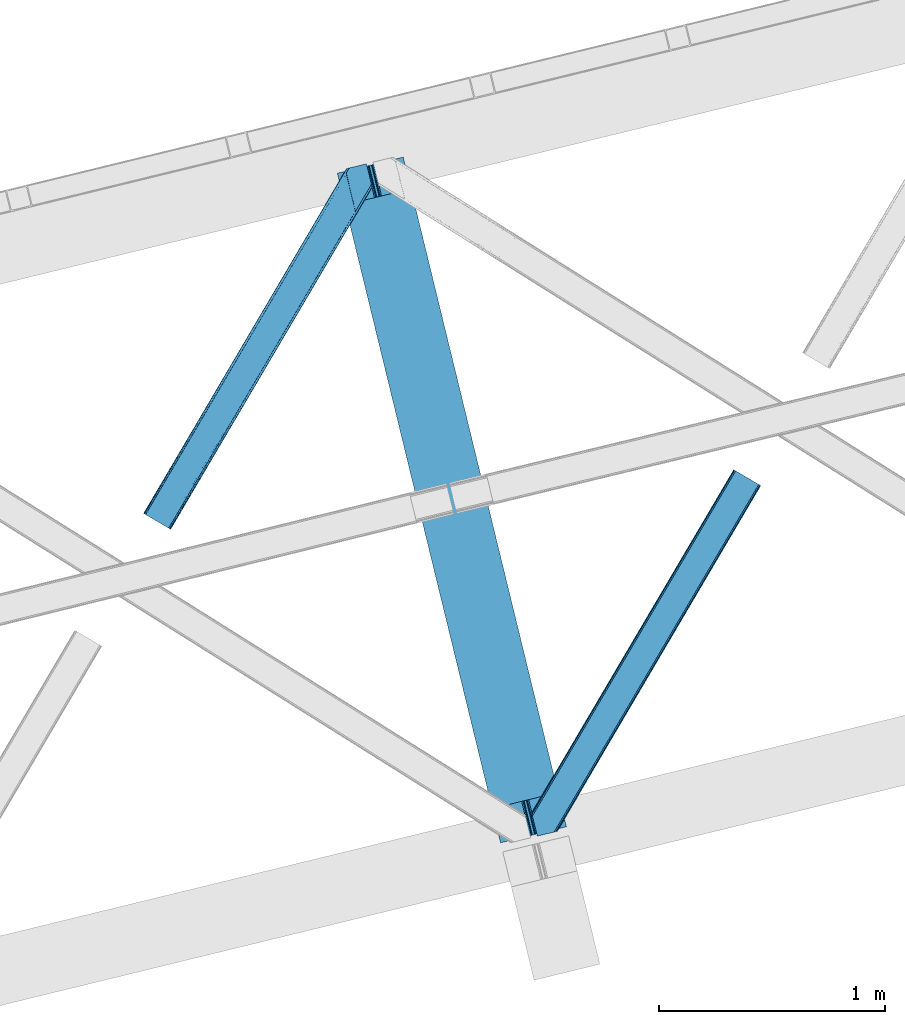
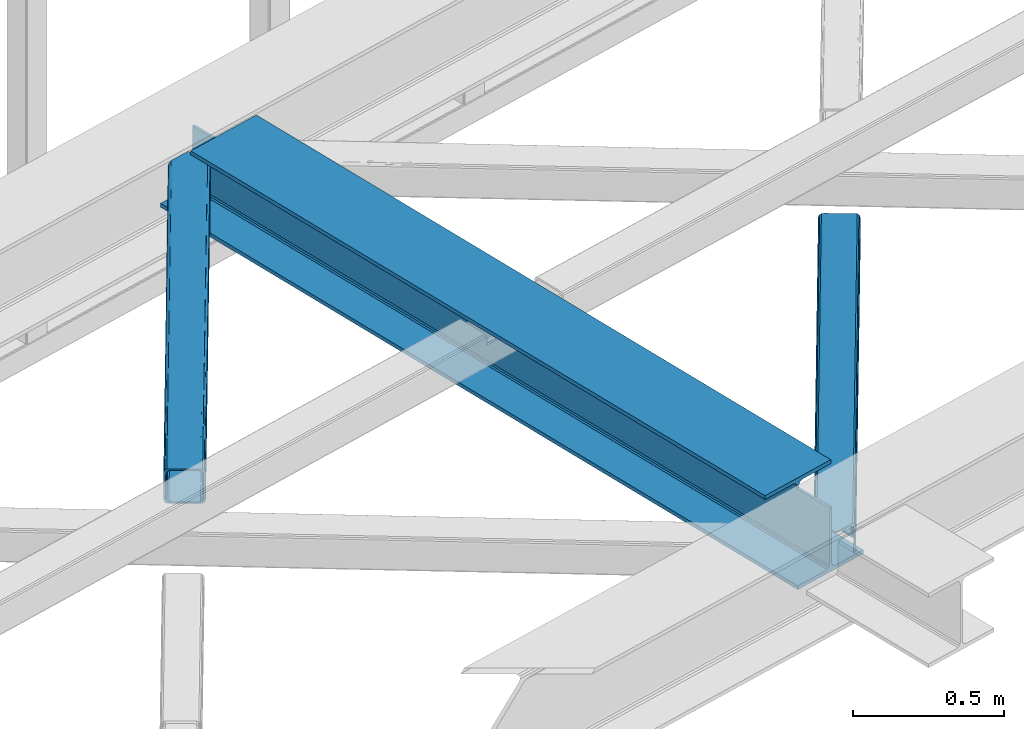
# One storey, part 19 of 66: 2 members, 1 beam.
"""IFC4 building model written with IfcOpenShell, lengths in millimetres."""

from ifc_helpers import new_model, entity, si_unit, converted_unit, derived_unit, direction, frame, origin, place, context, subcontext, project, spatial, triangles, polygons, material, type_object, element, save


model = new_model("IFC4")

# Units and contexts
model_context = context("Model", 3, precision=0.01, world=origin(), true_north=direction((6.12303176911189e-17, 1.0)))
plan_context = context("Plan", 3, precision=0.01, world=origin(), true_north=direction((6.12303176911189e-17, 1.0)))
body_context = subcontext(model_context, "Body", "Model", "MODEL_VIEW")
ifc_project = project(units=[si_unit("LENGTHUNIT", "METRE", prefix="MILLI"), si_unit("AREAUNIT", "SQUARE_METRE"), si_unit("VOLUMEUNIT", "CUBIC_METRE"), converted_unit("PLANEANGLEUNIT", "DEGREE", entity("IfcRatioMeasure", 0.0174532925199433), si_unit("PLANEANGLEUNIT", "RADIAN"), dimensions=[0, 0, 0, 0, 0, 0, 0]), si_unit("MASSUNIT", "GRAM", prefix="KILO"), derived_unit("MASSDENSITYUNIT", [(si_unit("MASSUNIT", "GRAM", prefix="KILO"), 1), (si_unit("LENGTHUNIT", "METRE"), -3)]), derived_unit("MOMENTOFINERTIAUNIT", [(si_unit("LENGTHUNIT", "METRE"), 4)]), si_unit("TIMEUNIT", "SECOND"), si_unit("FREQUENCYUNIT", "HERTZ"), si_unit("THERMODYNAMICTEMPERATUREUNIT", "DEGREE_CELSIUS"), derived_unit("THERMALTRANSMITTANCEUNIT", [(si_unit("MASSUNIT", "GRAM", prefix="KILO"), 1), (si_unit("THERMODYNAMICTEMPERATUREUNIT", "KELVIN"), -1), (si_unit("TIMEUNIT", "SECOND"), -3)]), derived_unit("VOLUMETRICFLOWRATEUNIT", [(si_unit("LENGTHUNIT", "METRE"), 3), (si_unit("TIMEUNIT", "SECOND"), -1)]), derived_unit("MASSFLOWRATEUNIT", [(si_unit("MASSUNIT", "GRAM", prefix="KILO"), 1), (si_unit("TIMEUNIT", "SECOND"), -1)]), derived_unit("ROTATIONALFREQUENCYUNIT", [(si_unit("TIMEUNIT", "SECOND"), -1)]), si_unit("ELECTRICCURRENTUNIT", "AMPERE"), si_unit("ELECTRICVOLTAGEUNIT", "VOLT"), si_unit("POWERUNIT", "WATT"), si_unit("FORCEUNIT", "NEWTON", prefix="KILO"), si_unit("ILLUMINANCEUNIT", "LUX"), si_unit("LUMINOUSFLUXUNIT", "LUMEN"), si_unit("LUMINOUSINTENSITYUNIT", "CANDELA"), derived_unit("USERDEFINED", [(si_unit("MASSUNIT", "GRAM", prefix="KILO"), -1), (si_unit("LENGTHUNIT", "METRE"), -2), (si_unit("TIMEUNIT", "SECOND"), 3), (si_unit("LUMINOUSFLUXUNIT", "LUMEN"), 1)]), derived_unit("LINEARVELOCITYUNIT", [(si_unit("LENGTHUNIT", "METRE"), 1), (si_unit("TIMEUNIT", "SECOND"), -1)]), si_unit("PRESSUREUNIT", "PASCAL"), derived_unit("USERDEFINED", [(si_unit("LENGTHUNIT", "METRE"), -2), (si_unit("MASSUNIT", "GRAM", prefix="KILO"), 1), (si_unit("TIMEUNIT", "SECOND"), -2)]), derived_unit("LINEARFORCEUNIT", [(si_unit("MASSUNIT", "GRAM", prefix="KILO"), 1), (si_unit("LENGTHUNIT", "METRE"), 1), (si_unit("TIMEUNIT", "SECOND"), -2), (si_unit("LENGTHUNIT", "METRE"), -1)]), derived_unit("PLANARFORCEUNIT", [(si_unit("MASSUNIT", "GRAM", prefix="KILO"), 1), (si_unit("LENGTHUNIT", "METRE"), 1), (si_unit("TIMEUNIT", "SECOND"), -2), (si_unit("LENGTHUNIT", "METRE"), -2)])], contexts=[model_context, plan_context])

# Site, building, storey
site_placement = place(None, origin())
site = spatial("IfcSite", under=ifc_project, at=site_placement, CompositionType="ELEMENT")
building_placement = place(site_placement, origin())
building = spatial("IfcBuilding", under=site, at=building_placement, CompositionType="ELEMENT")
storey_placement = place(building_placement, frame((0.0, 0.0, 19800.0)))
storey = spatial("IfcBuildingStorey", under=building, at=storey_placement, Name="06", CompositionType="ELEMENT", Elevation=19800.0)

# Beam
ifc_material = material(Name="Metal painted (White)")
beam_type = type_object("IfcBeamType", PredefinedType="BEAM")
beam_placement = place(storey_placement, frame((-58234.78, 3608.48, 3807.02)))
element("IfcBeam", 1, at=beam_placement, inside=storey, type_object=beam_type, material=ifc_material, ObjectType="Steel Beam", PredefinedType="BEAM", context=body_context, shape_type="Tessellation", body=[
    polygons([(291.465617442438, 3033.06716515592, 15.5000000000008), (1013.48916844672, 71.047827897101, 15.5000000000008), (1013.48916844672, 71.047827897101, 0.0), (291.465617442438, 3033.06716515592, 0.0), (168.078506058465, 3002.99025134615, 15.5000000000008), (890.102057062761, 40.9709140873291, 15.5000000000008), (883.409713288798, 39.3395844888243, 16.8701684147984), (161.386162284511, 3001.35892174764, 16.8701684147984), (877.736218188182, 37.9566100336502, 20.7720779386434), (155.712667183895, 2999.97594729247, 20.7720779386434), (873.945309959616, 37.0325360459167, 26.6116982174294), (151.92175895532, 2999.05187330474, 26.6116982174294), (872.614120016219, 36.7080444135018, 33.500000000001), (150.590569011932, 2998.72738167232, 33.500000000001), (140.875048430505, 2996.35912074242, 33.500000000001), (140.875048430505, 2996.35912074242, 259.000000000002), (150.590569011932, 2998.72738167232, 259.000000000002), (0.0, 2962.01933725882, 0.0), (0.0, 2962.01933725882, 15.4999999999965), (123.387111383964, 2992.09625106859, 15.5000000000008), (130.079455157926, 2993.7275806671, 16.8701684147984), (135.752950258542, 2995.11055512227, 20.7720779386434), (139.543858487109, 2996.03462911, 26.6116982174294), (862.898599434792, 34.3397834835981, 259.000000000002), (862.898599434792, 34.3397834835992, 33.500000000001), (861.567409491404, 34.0152918511837, 26.6116982174294), (857.776501262829, 33.0912178634502, 20.7720779386434), (852.103006162213, 31.7082434082767, 16.8701684147984), (845.410662388251, 30.0769138097719, 15.5000000000008), (722.023551004287, 0.0, 15.4999999999965), (722.023551004287, 5.41433564649196e-13, 0.0), (872.614120016219, 36.7080444135018, 259.000000000002), (184.336875281427, 2860.28691509782, 264.979820882044), (184.752732925781, 2858.58099728541, 264.979776108577), (184.752732925781, 2858.58099728541, 266.5), (835.611083878222, 188.508783434825, 266.500002998871), (835.611433998983, 188.507347130091, 260.000004007589), (835.756262659236, 187.913305519903, 259.069792895655), (184.10148419006, 2861.25277281279, 259.006343165873), (184.321671892423, 2860.34946683221, 259.617271795417), (175.037212344371, 2856.21273635551, 264.979776108577), (174.624287332073, 2857.90681193203, 264.979727889257), (174.621246070538, 2857.91909282363, 260.000048218074), (174.476547052887, 2858.51270029145, 259.069794411205), (826.131325439436, 185.173233288697, 259.006343169741), (825.907955396203, 186.089684915033, 259.617303331124), (825.895566552569, 186.140509148806, 266.500003008253), (175.037212344371, 2856.21273635551, 266.5), (173.706022400984, 2855.8882447231, 273.388301782572), (169.915114172408, 2854.96417073536, 279.227922061358), (164.241619071775, 2853.58119628019, 283.129831585203), (157.549275297821, 2851.94986668168, 284.5), (34.1621639138576, 2821.87295287191, 284.5), (34.1621639138576, 2821.87295287191, 300.000000000001), (325.627781356295, 2892.92078076901, 300.000000000001), (325.627781356295, 2892.92078076901, 284.5), (202.240669972323, 2862.84386695924, 284.5), (195.548326198377, 2861.21253736074, 283.129831585203), (189.874831097753, 2859.82956290556, 279.227922061358), (186.083922869178, 2858.90548891783, 273.388301782572), (836.942571748158, 188.832052879511, 273.388305639783), (840.732848336854, 189.758718051425, 279.227924098781), (846.405919284392, 191.143432515101, 283.129832400619), (853.098110965509, 192.775386045914, 284.500000377228), (976.485139653361, 222.852639101025, 284.500000138971), (976.483469846701, 222.859489169757, 299.999995328161), (685.018047749439, 151.810859905715, 299.999995890962), (685.019717556091, 151.804009836983, 284.500000701776), (808.406746243935, 181.881262892094, 284.500000463519), (815.099233140082, 183.512005358672, 283.129832461069), (820.773144788834, 184.893271003198, 279.227924137322), (824.564679575826, 185.814774652495, 273.388305663684)], [[[1, 2, 3, 4]], [[5, 6, 2, 1]], [[7, 6, 5, 8]], [[9, 7, 8, 10]], [[11, 9, 10, 12]], [[13, 11, 12, 14]], [[15, 16, 17, 14, 12, 10, 8, 5, 1, 4, 18, 19, 20, 21, 22, 23]], [[24, 25, 26, 27, 28, 29, 30, 31, 3, 2, 6, 7, 9, 11, 13, 32]], [[4, 3, 31, 18]], [[18, 31, 30, 19]], [[19, 30, 29, 20]], [[26, 25, 15, 23]], [[27, 26, 23, 22]], [[28, 27, 22, 21]], [[29, 28, 21, 20]], [[33, 34, 35, 36, 37, 38, 32, 13, 14, 17, 39, 40]], [[41, 42, 43, 44, 16, 15, 25, 24, 45, 46, 47, 48]], [[44, 39, 17, 16]], [[42, 33, 40, 43]], [[42, 41, 34, 33]], [[45, 24, 32, 38]], [[41, 48, 49, 50, 51, 52, 53, 54, 55, 56, 57, 58, 59, 60, 35, 34]], [[47, 46, 37, 36, 61, 62, 63, 64, 65, 66, 67, 68, 69, 70, 71, 72]], [[61, 36, 35, 60]], [[62, 61, 60, 59]], [[63, 62, 59, 58]], [[64, 63, 58, 57]], [[57, 56, 65, 64]], [[56, 55, 66, 65]], [[55, 54, 67, 66]], [[54, 53, 68, 67]], [[53, 52, 69, 68]], [[70, 69, 52, 51]], [[71, 70, 51, 50]], [[72, 71, 50, 49]], [[47, 72, 49, 48]]], closed=False),
])

# Members
member_type_1 = type_object("IfcMemberType", PredefinedType="BRACE")
member_1_placement = place(storey_placement, frame((-59092.24, 4994.99, 3824.0)))
element("IfcMember", 2, at=member_1_placement, inside=storey, type_object=member_type_1, ObjectType="Steel Horizontal Brace", PredefinedType="BRACE", context=body_context, shape_type="Tessellation", body=[
    triangles([(105.565649414064, 8.87794647216742, 0.0), (15.0828002929702, 62.1479507446284, 0.0), (892.847827148435, 1346.1393447876, 0.0), (857.170935058595, 1492.50250396728, 0.0), (854.896655273435, 1501.83739929199, 1.33247680664135), (9.31105957031104, 65.5459991455073, 1.33247680664135), (852.966540527341, 1509.75145111084, 5.12526855468968), (4.4183349609375, 68.4260559082031, 5.12526855468968), (851.678247070311, 1515.03950042725, 10.8039916992202), (1.14876708984229, 70.3509384155268, 10.8039916992202), (851.222460937497, 1516.89636383057, 17.5012573242202), (0.0, 71.0264785766603, 17.5012573242202), (893.638476562497, 1342.89768218994, 0.155804443358647), (111.337390136716, 5.48047943115216, 1.33247680664135), (899.559045410155, 1344.34119873047, 1.33247680664135), (912.390820312503, 1347.46949615478, 10.8039916992202), (914.195361328122, 1347.90958557129, 17.5012573242202), (120.643798828125, 0.0, 17.5012573242202), (119.499682617185, 0.675540161132631, 10.8039916992202), (907.251599121097, 1346.21666564941, 5.12526855468968), (116.230114746089, 2.59984130859357, 5.12526855468968), (902.498400878903, 1345.05743408203, 17.9802978515618), (893.638476562497, 1342.89768218994, 9.69243164062573), (897.768457031249, 1343.90459747314, 12.1248413085959), (903.726232910158, 1345.35625305176, 19.5011352539077), (914.195361328122, 1347.90958557129, 19.5011352539077), (1011.61732177735, 1513.38611297607, 19.5011352539077), (1008.98957519532, 1524.16103668213, 19.5011352539077), (1011.61732177735, 1513.38611297607, 122.499499511719), (120.643798828125, 0.0, 122.499499511719), (114.61160888672, 3.55094604492206, 24.5008300781265), (1009.24072265625, 1523.14365692139, 24.5008300781265), (113.46749267578, 4.22706756591742, 17.8035644531265), (110.197924804685, 6.15136871337836, 12.1248413085959), (105.305200195311, 9.03200683593695, 8.3320495605476), (99.5334594726519, 12.4294738769531, 6.99957275390625), (892.685046386716, 1346.79976959229, 8.8831787109375), (890.471228027345, 1355.89688873291, 6.99957275390625), (21.114990234375, 58.5970046997072, 6.99957275390625), (859.547534179685, 1482.74496002197, 6.99957275390625), (853.961828613283, 1505.65984039307, 18.501196289064), (851.222460937497, 1516.89636383057, 18.501196289064), (854.096704101561, 1505.10871124268, 17.8803039550803), (855.343139648438, 1499.99390716553, 12.1248413085959), (857.273254394531, 1492.07985534668, 8.3320495605476), (1009.24072265625, 1523.14365692139, 115.499926757813), (114.61160888672, 3.55094604492206, 115.499926757813), (1008.78493652344, 1525.00052032471, 122.197192382813), (113.46749267578, 4.22706756591742, 122.197192382813), (1007.49664306641, 1530.28856964111, 127.873590087893), (110.197924804685, 6.15136871337836, 127.873590087893), (1005.57117919922, 1538.20262145996, 131.668707275392), (105.305200195311, 9.03200683593695, 131.668707275392), (1003.29224853516, 1547.53751678467, 133.001184082033), (99.5334594726519, 12.4294738769531, 133.001184082033), (851.952648925784, 1518.13291625977, 19.5011352539077), (854.580395507815, 1507.35799255371, 19.5011352539077), (851.780566406247, 1517.83991088867, 19.2639404296897), (854.43156738281, 1506.94987792969, 19.2592895507805), (851.589880371095, 1517.51434936523, 19.0011657714858), (854.268786621091, 1506.50920715332, 19.0011657714858), (851.394543457034, 1517.1887878418, 18.7360656738274), (854.110656738281, 1506.06795501709, 18.7407165527366), (908.014343261719, 1598.12628936768, 19.5011352539077), (897.545214843747, 1595.57353820801, 19.5011352539077), (1011.16618652343, 1515.24297637939, 129.196765136719), (1009.8778930664, 1520.53160705566, 134.87548828125), (1008.43146972657, 1526.45624542236, 138.000878906252), (986.311889648438, 1617.21117095947, 138.000878906252), (986.311889648438, 1617.21117095947, 133.001184082033), (897.545214843747, 1595.57353820801, 122.499499511719), (0.0, 71.0264785766603, 122.499499511719), (7.18095703124709, 66.799411010742, 17.8035644531265), (10.4505249023423, 64.8751098632811, 12.1248413085959), (6.03218994140479, 67.4755325317383, 24.5008300781265), (907.028356933595, 1597.88560638428, 24.5008300781265), (15.3432495117158, 61.9944717407225, 8.3320495605476), (908.832897949222, 1598.32511444092, 122.197192382813), (899.349755859374, 1596.01362762451, 129.196765136719), (904.48897705078, 1597.26645812988, 134.87548828125), (930.738537597659, 1603.66490478516, 133.001184082033), (910.246765136719, 1598.66986083984, 138.000878906252), (921.664672851563, 1601.45341186523, 131.668707275392), (913.972119140628, 1599.57794494629, 127.873590087893), (907.028356933595, 1597.88560638428, 115.499926757813), (21.114990234375, 58.5970046997072, 133.001184082033), (6.03218994140479, 67.4755325317383, 115.499926757813), (15.3432495117158, 61.9944717407225, 131.668707275392), (10.4505249023423, 64.8751098632811, 127.873590087893), (7.18095703124709, 66.799411010742, 122.197192382813), (119.499682617185, 0.675540161132631, 129.196765136719), (116.230114746089, 2.59984130859357, 134.87548828125), (111.337390136716, 5.48047943115216, 138.668280029298), (105.565649414064, 8.87794647216742, 140.00075683594), (15.0828002929702, 62.1479507446284, 140.00075683594), (9.31105957031104, 65.5459991455073, 138.668280029298), (4.4183349609375, 68.4260559082031, 134.87548828125), (1.14876708984229, 70.3509384155268, 129.196765136719), (896.991760253906, 1576.15553741455, 138.000878906252), (938.18924560547, 1407.14434204102, 138.000878906252), (899.024194335936, 1563.5946762085, 140.00075683594), (897.042919921878, 1571.72266845703, 139.000817871096), (896.801074218747, 1573.13653564453, 138.638049316407), (896.926647949222, 1575.15443572998, 138.212493896484), (896.86153564453, 1574.14112548828, 138.426434326171), (937.477661132813, 1407.08562469482, 138.293884277344), (937.077685546872, 1408.09486541748, 138.647351074218), (936.682360839841, 1409.10410614014, 139.000817871096), (934.701086425783, 1417.23209838867, 140.00075683594)], [[1, 2, 3], [4, 3, 2], [5, 4, 6], [2, 6, 4], [7, 5, 8], [6, 8, 5], [9, 7, 10], [8, 10, 7], [11, 9, 12], [10, 12, 9], [1, 3, 13], [13, 14, 1], [13, 15, 14], [16, 17, 18], [18, 19, 16], [20, 16, 19], [19, 21, 20], [15, 20, 21], [21, 14, 15], [20, 22, 16], [23, 24, 15], [23, 15, 13], [15, 24, 20], [16, 25, 17], [20, 24, 22], [16, 22, 25], [26, 17, 25], [26, 25, 27], [28, 27, 25], [27, 29, 26], [30, 26, 29], [26, 18, 17], [30, 18, 26], [31, 32, 25], [25, 33, 31], [25, 22, 33], [32, 28, 25], [33, 22, 24], [34, 24, 23], [23, 35, 34], [36, 35, 37], [37, 38, 36], [23, 37, 35], [24, 34, 33], [39, 36, 38], [38, 40, 39], [9, 11, 41], [11, 42, 41], [43, 9, 41], [43, 7, 9], [44, 7, 43], [5, 44, 45], [44, 5, 7], [4, 5, 45], [45, 40, 4], [37, 23, 13], [37, 3, 38], [3, 40, 38], [40, 3, 4], [37, 13, 3], [46, 32, 31], [31, 47, 46], [48, 46, 49], [47, 49, 46], [50, 48, 51], [49, 51, 48], [52, 50, 53], [51, 53, 50], [54, 52, 55], [53, 55, 52], [56, 57, 58], [59, 58, 57], [58, 59, 60], [61, 60, 59], [60, 61, 62], [63, 62, 61], [62, 63, 42], [41, 42, 63], [57, 56, 64], [65, 64, 56], [66, 48, 67], [46, 29, 27], [27, 32, 46], [32, 27, 28], [48, 29, 46], [66, 29, 48], [50, 68, 67], [52, 68, 50], [67, 48, 50], [52, 54, 68], [54, 69, 68], [70, 69, 54], [71, 60, 62], [58, 60, 71], [71, 56, 58], [56, 71, 65], [42, 12, 72], [12, 42, 11], [71, 42, 72], [42, 71, 62], [73, 74, 44], [75, 73, 43], [43, 41, 75], [43, 57, 75], [64, 76, 57], [75, 57, 76], [44, 43, 73], [45, 44, 74], [74, 77, 45], [40, 45, 77], [77, 39, 40], [78, 79, 80], [81, 82, 69], [69, 70, 81], [81, 83, 82], [84, 82, 83], [80, 82, 84], [78, 71, 79], [85, 71, 78], [80, 84, 78], [65, 76, 64], [85, 65, 71], [76, 65, 85], [86, 54, 55], [54, 86, 81], [70, 54, 81], [76, 85, 75], [87, 75, 85], [83, 81, 86], [86, 88, 83], [84, 83, 88], [88, 89, 84], [78, 84, 89], [89, 90, 78], [85, 78, 90], [90, 87, 85], [91, 51, 49], [47, 18, 30], [91, 49, 30], [91, 92, 51], [49, 47, 30], [51, 92, 93], [55, 94, 95], [94, 53, 93], [53, 94, 55], [53, 51, 93], [19, 34, 21], [31, 18, 47], [18, 33, 19], [33, 18, 31], [19, 33, 34], [1, 36, 2], [14, 21, 34], [34, 35, 14], [35, 36, 1], [1, 14, 35], [89, 96, 97], [95, 86, 55], [95, 88, 86], [88, 95, 96], [89, 88, 96], [87, 72, 12], [98, 90, 89], [97, 98, 89], [90, 98, 72], [87, 90, 72], [6, 74, 8], [2, 36, 39], [39, 77, 2], [77, 74, 6], [6, 2, 77], [10, 8, 74], [12, 75, 87], [73, 12, 10], [12, 73, 75], [73, 10, 74], [99, 68, 82], [99, 100, 68], [68, 69, 82], [96, 95, 101], [101, 102, 96], [97, 96, 103], [104, 97, 105], [104, 99, 97], [97, 103, 105], [82, 80, 99], [97, 99, 80], [102, 103, 96], [79, 71, 98], [72, 98, 71], [80, 79, 97], [98, 97, 79], [92, 67, 100], [100, 93, 92], [67, 68, 100], [106, 107, 93], [94, 93, 107], [107, 108, 94], [108, 109, 94], [66, 67, 92], [92, 91, 66], [29, 66, 91], [91, 30, 29], [95, 94, 109], [109, 101, 95], [107, 103, 102], [105, 103, 107], [106, 104, 105], [100, 99, 104], [107, 106, 105], [102, 108, 107], [102, 101, 109], [109, 108, 102]]),
])
member_type_2 = type_object("IfcMemberType", PredefinedType="BRACE")
member_2_placement = place(storey_placement, frame((-57375.4, 3638.1, 3824.0)))
element("IfcMember", 3, at=member_2_placement, inside=storey, type_object=member_type_2, ObjectType="Steel Horizontal Brace", PredefinedType="BRACE", context=body_context, shape_type="Tessellation", body=[
    triangles([(154.446386718751, 124.708666992188, 0.0), (118.769494628905, 271.071535491943, 0.0), (998.971582031249, 1559.19843292236, 0.0), (908.488732910155, 1612.46901855469, 0.0), (1004.74332275391, 1555.80096588135, 1.33247680664135), (156.725317382814, 115.37377166748, 1.33247680664135), (1009.63604736328, 1552.92090911865, 5.12526855468968), (158.650781249999, 107.459719848633, 5.12526855468968), (1012.90561523438, 1550.99602661133, 10.8039916992202), (159.943725585938, 102.171670532227, 10.8039916992202), (1014.05438232422, 1550.3204864502, 17.5012573242202), (160.394860839842, 100.314807128907, 17.5012573242202), (902.716992187503, 1615.8664855957, 1.33247680664135), (116.495214843751, 280.406721496582, 1.33247680664135), (114.574401855469, 288.275717926026, 5.1694519042976), (897.824267578122, 1618.74712371826, 5.12526855468968), (114.499987792966, 288.596628570557, 5.32758178711083), (894.554699707034, 1620.67142486572, 10.8039916992202), (109.625866699222, 287.409201049805, 10.8039916992202), (893.405932617185, 1621.34696502686, 17.5012573242202), (107.821325683595, 286.969111633301, 17.5012573242202), (113.527954101563, 288.35972442627, 18.5197998046897), (114.499987792966, 288.596628570557, 17.5198608398459), (114.42557373047, 288.578606414795, 17.9035583496116), (114.216284179689, 288.527156066895, 18.2267944335945), (113.900024414063, 288.450416564941, 18.4453857421868), (107.821325683595, 286.969111633301, 18.5197998046897), (115.695263671878, 283.683556365967, 17.5198608398459), (115.625500488284, 283.800409698486, 17.8035644531265), (115.565039062501, 283.740529632569, 17.8570495605491), (115.323193359378, 283.495777130127, 18.0779663085959), (115.067395019534, 283.23939743042, 18.3081848144539), (114.834851074222, 283.003074645996, 18.5197998046897), (0.0, 103.824767303467, 18.5197998046897), (2.73471679687646, 92.5989990234375, 18.5197998046897), (893.405932617185, 1621.34696502686, 122.499499511719), (0.0, 103.824767303467, 122.499499511719), (908.488732910155, 1612.46901855469, 140.00075683594), (902.716992187503, 1615.8664855957, 138.668280029298), (3.66954345702834, 88.7660934448245, 138.668280029298), (5.94847412109084, 79.4309074401858, 140.00075683594), (897.824267578122, 1618.74712371826, 134.87548828125), (1.73942871093459, 96.6798545837405, 134.87548828125), (894.554699707034, 1620.67142486572, 129.196765136719), (0.451135253904795, 101.967903900147, 129.196765136719), (899.438122558597, 1617.79601898193, 24.5008300781265), (2.37659912109666, 94.0672233581545, 24.5008300781265), (900.586889648439, 1617.11989746094, 17.8035644531265), (903.856457519534, 1615.19559631348, 12.1248413085959), (914.52092285156, 1608.9174911499, 6.99957275390625), (908.749182128908, 1612.31495819092, 8.3320495605476), (118.871813964841, 270.64917755127, 8.3320495605476), (121.150744628903, 261.313991546631, 6.99957275390625), (116.946350097656, 278.562938690186, 12.1248413085959), (152.069787597655, 134.4662109375, 6.99957275390625), (992.939392089844, 1562.74996032715, 6.99957275390625), (156.274182128909, 117.217263793946, 12.1248413085959), (154.344067382815, 125.131024932862, 8.3320495605476), (157.520617675778, 112.096646118164, 17.5198608398459), (160.394860839842, 100.314807128907, 17.5198608398459), (899.438122558597, 1617.79601898193, 115.499926757813), (2.37659912109666, 94.0672233581545, 115.499926757813), (900.586889648439, 1617.11989746094, 122.197192382813), (2.83238525390334, 92.2103599548341, 122.197192382813), (903.856457519534, 1615.19559631348, 127.873590087893), (4.12067871094041, 86.9223106384279, 127.873590087893), (908.749182128908, 1612.31495819092, 131.668707275392), (6.05079345703416, 79.0085494995119, 131.668707275392), (914.52092285156, 1608.9174911499, 133.001184082033), (8.3250732421875, 69.6733634948732, 133.001184082033), (25.310083007811, 0.0, 133.001184082033), (25.310083007811, 0.0, 140.00075683594), (90.3665771484375, 15.8580436706543, 140.00075683594), (998.971582031249, 1559.19843292236, 140.00075683594), (1014.05438232422, 1550.3204864502, 122.499499511719), (1012.90561523438, 1550.99602661133, 129.196765136719), (114.076757812501, 21.6376327514649, 122.499499511719), (112.267565917966, 21.1978340148926, 129.196765136719), (1009.63604736328, 1552.92090911865, 134.87548828125), (107.12834472656, 19.9450035095215, 134.87548828125), (1004.74332275391, 1555.80096588135, 138.668280029298), (99.435791015625, 18.0698272705081, 138.668280029298), (159.664672851563, 99.0785453796389, 18.5197998046897), (114.076757812501, 21.6376327514649, 18.5197998046897), (103.161145019534, 18.9779113769532, 18.5197998046897), (156.929956054686, 110.304313659668, 18.5197998046897), (1008.02219238281, 1553.87143249512, 24.5008300781265), (1006.87342529297, 1554.54755401611, 17.8035644531265), (1003.60385742188, 1556.47185516357, 12.1248413085959), (998.711132812503, 1559.35249328613, 8.3320495605476), (104.588964843751, 19.325855255127, 24.5008300781265), (1003.60385742188, 1556.47185516357, 127.873590087893), (1008.02219238281, 1553.87143249512, 115.499926757813), (1006.87342529297, 1554.54755401611, 122.197192382813), (992.939392089844, 1562.74996032715, 133.001184082033), (998.711132812503, 1559.35249328613, 131.668707275392), (102.784423828125, 18.8860565185546, 122.197192382813), (80.8787841796875, 13.5462661743163, 133.001184082033), (89.9526489257842, 15.7580497741701, 131.668707275392), (97.6452026367188, 17.6329353332521, 127.873590087893), (104.588964843751, 19.325855255127, 115.499926757813)], [[1, 2, 3], [4, 3, 2], [3, 5, 1], [6, 1, 5], [5, 7, 6], [8, 6, 7], [7, 9, 8], [10, 8, 9], [9, 11, 10], [12, 10, 11], [13, 14, 15], [16, 15, 17], [17, 18, 16], [17, 19, 18], [20, 18, 19], [19, 21, 20], [15, 16, 13], [13, 4, 14], [2, 14, 4], [22, 23, 24], [22, 25, 26], [27, 21, 22], [24, 25, 22], [23, 22, 21], [21, 19, 23], [17, 23, 19], [23, 28, 29], [29, 24, 23], [25, 24, 30], [26, 25, 31], [22, 26, 32], [32, 33, 22], [31, 32, 26], [30, 31, 25], [29, 30, 24], [34, 33, 35], [33, 34, 27], [22, 33, 27], [27, 20, 21], [36, 27, 37], [27, 36, 20], [27, 34, 37], [38, 39, 40], [40, 41, 38], [39, 42, 43], [43, 40, 39], [42, 44, 45], [45, 43, 42], [44, 36, 37], [37, 45, 44], [46, 47, 33], [33, 48, 46], [33, 31, 48], [47, 35, 33], [49, 48, 28], [50, 51, 52], [52, 53, 50], [51, 49, 54], [54, 52, 51], [28, 54, 49], [53, 55, 56], [56, 50, 53], [55, 2, 1], [54, 17, 14], [52, 14, 2], [52, 2, 53], [55, 53, 2], [17, 28, 23], [54, 28, 17], [52, 54, 14], [57, 58, 6], [58, 1, 6], [1, 58, 55], [8, 57, 6], [8, 59, 57], [10, 59, 8], [10, 60, 59], [46, 61, 47], [62, 47, 61], [61, 63, 62], [64, 62, 63], [63, 65, 64], [66, 64, 65], [65, 67, 66], [68, 66, 67], [67, 69, 68], [70, 68, 69], [66, 43, 64], [71, 72, 70], [72, 41, 70], [40, 68, 41], [66, 68, 40], [68, 70, 41], [66, 40, 43], [37, 34, 62], [45, 64, 43], [62, 64, 37], [64, 45, 37], [34, 47, 62], [34, 35, 47], [41, 73, 74], [73, 41, 72], [74, 38, 41], [75, 76, 77], [78, 77, 76], [76, 79, 78], [80, 78, 79], [79, 81, 80], [82, 80, 81], [81, 74, 82], [73, 82, 74], [60, 75, 77], [60, 11, 75], [77, 83, 60], [77, 84, 83], [84, 85, 83], [86, 83, 85], [87, 88, 59], [88, 89, 57], [57, 59, 88], [89, 90, 58], [58, 57, 89], [90, 56, 55], [55, 58, 90], [87, 86, 91], [85, 91, 86], [9, 89, 88], [87, 75, 11], [9, 88, 11], [9, 7, 89], [88, 87, 11], [89, 7, 5], [56, 3, 4], [3, 90, 5], [90, 3, 56], [90, 89, 5], [76, 92, 79], [93, 75, 87], [75, 94, 76], [94, 75, 93], [76, 94, 92], [74, 95, 38], [81, 79, 92], [92, 96, 81], [96, 95, 74], [74, 81, 96], [49, 13, 16], [4, 50, 56], [4, 51, 50], [51, 4, 13], [49, 51, 13], [46, 20, 36], [18, 48, 49], [16, 18, 49], [48, 18, 20], [46, 48, 20], [39, 65, 42], [38, 95, 69], [69, 67, 38], [67, 65, 39], [39, 38, 67], [44, 42, 65], [36, 61, 46], [63, 36, 44], [36, 63, 61], [63, 44, 65], [97, 78, 80], [98, 73, 72], [72, 71, 98], [98, 99, 73], [99, 82, 73], [100, 82, 99], [80, 82, 100], [97, 77, 78], [101, 77, 97], [80, 100, 97], [84, 91, 85], [101, 84, 77], [91, 84, 101], [98, 70, 95], [98, 71, 70], [69, 95, 70], [95, 96, 99], [99, 98, 95], [96, 92, 100], [100, 99, 96], [92, 94, 97], [97, 100, 92], [94, 93, 101], [101, 97, 94], [93, 87, 91], [91, 101, 93]]),
])

save(model, "model.ifc")
